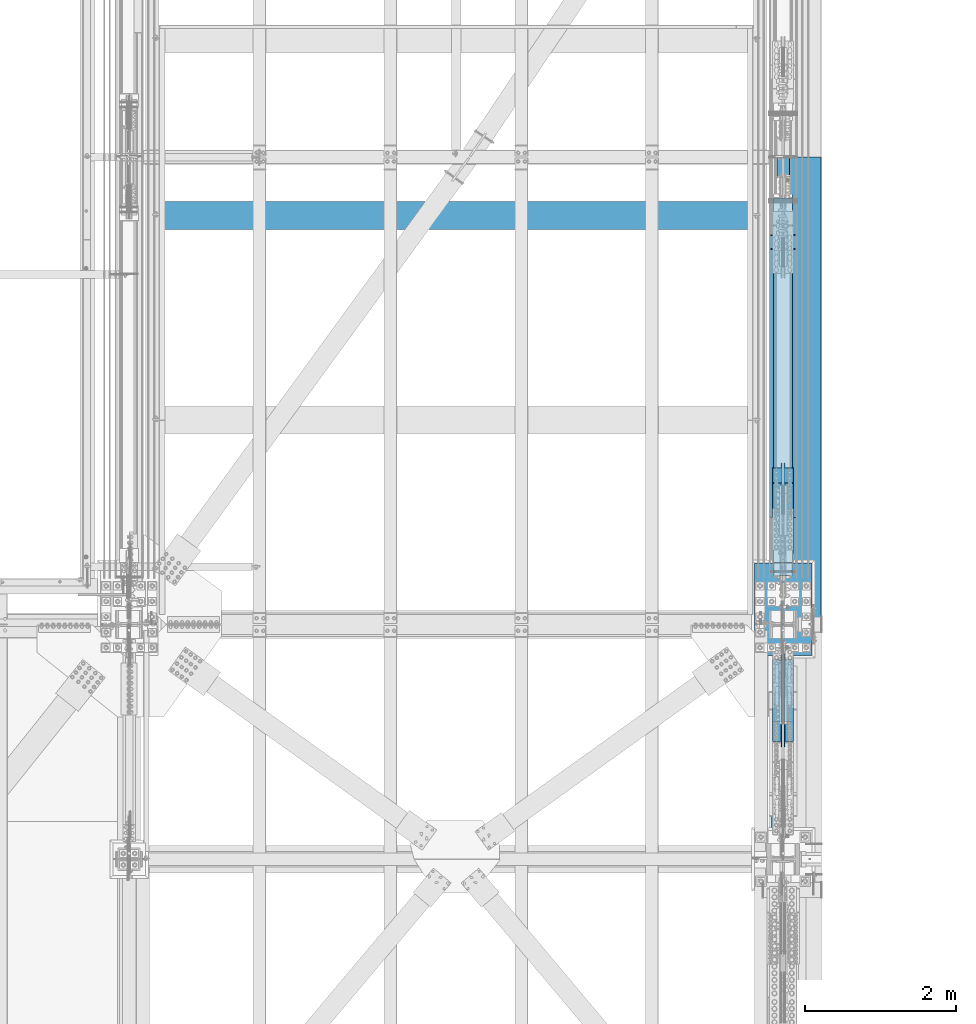
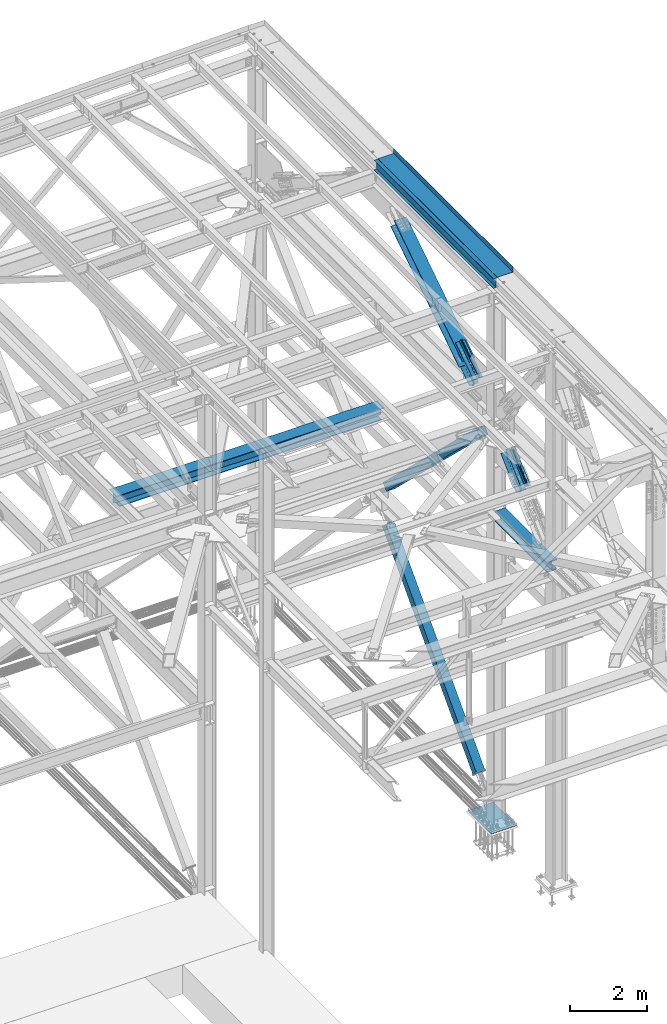
# One storey, part 1992 of 3843: 11 members, 5 beams, 8 elements without a shape of their own.
"""IFC2X3 building model written with IfcOpenShell, lengths in millimetres."""

import ifcopenshell
import ifcopenshell.guid

model = None  # the IFC model being written
_history = None  # IfcOwnerHistory: only IFC2X3 demands one
_inside = {}  # id of a spatial element -> (the spatial element, [elements in it])
_under = {}  # id of a project, library or spatial element -> (it, [spatial elements below it])
_declared = {}  # id of a project -> (the project, [libraries it declares])
_typed = {}  # id of a type object -> (the type object, [elements of that type])
_made_of = {}  # id of a material, layer set ... -> (it, [elements and type objects made of it])


def new_model(schema):
    """Start an empty IFC model of exactly this schema.

    Asked for "IFC4X3", IfcOpenShell would pick the latest addendum, in which some entities
    have other attributes; the version numbers below select the first issue.
    IFC2X3 requires an IfcOwnerHistory on every rooted entity: one is made here for all.
    """
    global model, _history
    if schema == "IFC4X3":
        model = ifcopenshell.file(schema_version=(4, 3, 0, 0))
    else:
        model = ifcopenshell.file(schema=schema)
    _inside.clear()
    _under.clear()
    _declared.clear()
    _typed.clear()
    _made_of.clear()
    _history = None
    if model.schema == "IFC2X3":
        org = make("IfcOrganization", Name="unknown")
        user = make(
            "IfcPersonAndOrganization",
            ThePerson=make("IfcPerson", FamilyName="unknown"),
            TheOrganization=org,
        )
        app = make(
            "IfcApplication",
            ApplicationDeveloper=org,
            Version="unknown",
            ApplicationFullName="unknown",
            ApplicationIdentifier="unknown",
        )
        _history = make(
            "IfcOwnerHistory",
            OwningUser=user,
            OwningApplication=app,
            ChangeAction="ADDED",
            CreationDate=0,
        )
    return model


def make(cls, **values):
    """One entity of the class cls with the attributes given. An attribute that is None is left unset."""
    return model.create_entity(
        cls, **{name: value for name, value in values.items() if value is not None}
    )


def rooted(cls, **values):
    """An entity with a GlobalId (a new one), such as an element, a storey or a relation."""
    return make(cls, GlobalId=ifcopenshell.guid.new(), OwnerHistory=_history, **values)


def si_unit(unit_type, name, prefix=None):
    """IfcSIUnit, for example si_unit("LENGTHUNIT", "METRE", prefix="MILLI")."""
    return make("IfcSIUnit", UnitType=unit_type, Prefix=prefix, Name=name)


def assignment(units):
    """IfcUnitAssignment: the units of a project."""
    return None if units is None else make("IfcUnitAssignment", Units=units)


def point(xyz):
    """IfcCartesianPoint."""
    return None if xyz is None else make("IfcCartesianPoint", Coordinates=xyz)


def direction(xyz):
    """IfcDirection."""
    return None if xyz is None else make("IfcDirection", DirectionRatios=xyz)


def frame(location, z_axis=None, x_axis=None):
    """IfcAxis2Placement3D, a coordinate frame: its origin and axes. An axis left out is left unset."""
    return make(
        "IfcAxis2Placement3D",
        Location=point(location),
        Axis=direction(z_axis),
        RefDirection=direction(x_axis),
    )


def origin_with_axes():
    """The frame at (0, 0, 0) with the z axis (0, 0, 1) and the x axis (1, 0, 0) written out."""
    return frame((0.0, 0.0, 0.0), z_axis=(0.0, 0.0, 1.0), x_axis=(1.0, 0.0, 0.0))


def place(relative_to, where):
    """IfcLocalPlacement: puts the frame where relative to a parent placement (None: the world)."""
    return make(
        "IfcLocalPlacement", PlacementRelTo=relative_to, RelativePlacement=where
    )


def context(
    kind, dimensions, precision=None, world=None, true_north=None, identifier=None
):
    """IfcGeometricRepresentationContext, for example the 3D "Model" context."""
    return make(
        "IfcGeometricRepresentationContext",
        ContextIdentifier=identifier,
        ContextType=kind,
        CoordinateSpaceDimension=dimensions,
        Precision=precision,
        WorldCoordinateSystem=world,
        TrueNorth=true_north,
    )


def subcontext(parent, identifier, kind, view, scale=None):
    """IfcGeometricRepresentationSubContext, for example "Body" below "Model"."""
    return make(
        "IfcGeometricRepresentationSubContext",
        ContextIdentifier=identifier,
        ContextType=kind,
        ParentContext=parent,
        TargetScale=scale,
        TargetView=view,
    )


def project(units=None, contexts=None):
    """IfcProject with its units and contexts."""
    return rooted(
        "IfcProject",
        Name="project",
        RepresentationContexts=contexts,
        UnitsInContext=assignment(units),
    )


def spatial(cls, under=None, at=None, **own):
    """A site, building, storey or space (cls), placed at a placement, below another one or the project."""
    s = rooted(cls, ObjectPlacement=at, **own)
    if under is not None:
        _under.setdefault(under.id(), (under, []))[1].append(s)
    return s


def faces_of(points, faces, orient=None, outer=None):
    """IfcFace entities. A face is a list of loops; a loop is a list of indices into points, from 0.

    orient and outer hold one flag for each loop. By default every Orientation is true, the
    first loop of a face is its IfcFaceOuterBound and the others are IfcFaceBound.
    """
    made = []
    for i, loops in enumerate(faces):
        bounds = []
        for j, loop in enumerate(loops):
            is_outer = j == 0 if outer is None else outer[i][j]
            bounds.append(
                make(
                    "IfcFaceOuterBound" if is_outer else "IfcFaceBound",
                    Bound=make("IfcPolyLoop", Polygon=[points[k] for k in loop]),
                    Orientation=True if orient is None else orient[i][j],
                )
            )
        made.append(make("IfcFace", Bounds=bounds))
    return made


def faceted_brep(points, faces, orient=None, outer=None, voids=None):
    """IfcFacetedBrep: a solid bounded by flat faces; with voids (closed shells), ...WithVoids."""
    shared = [point(p) for p in points]
    hull = make("IfcClosedShell", CfsFaces=faces_of(shared, faces, orient, outer))
    if voids is None:
        return make("IfcFacetedBrep", Outer=hull)
    return make(
        "IfcFacetedBrepWithVoids",
        Outer=hull,
        Voids=[
            make(cls, CfsFaces=faces_of(shared, fs, o, b)) for cls, fs, o, b in voids
        ],
    )


def shape(context_of_items, identifier, shape_type, items):
    """IfcShapeRepresentation: the items that make up one representation, for example the "Body"."""
    return make(
        "IfcShapeRepresentation",
        ContextOfItems=context_of_items,
        RepresentationIdentifier=identifier,
        RepresentationType=shape_type,
        Items=items,
    )


def material(Name=None, Category=None):
    """IfcMaterial."""
    return make("IfcMaterial", Name=Name, Category=Category)


def made_of(thing, what):
    """Note that an element or type object is made of a material, layer set ...; save() writes the relation."""
    if what is not None:
        _made_of.setdefault(what.id(), (what, []))[1].append(thing)
    return thing


def type_object(cls, material=None, **own):
    """A type object (cls), such as IfcWallType, which elements share."""
    return made_of(rooted(cls, **own), material)


def element(
    cls,
    number,
    at=None,
    inside=None,
    cuts=None,
    type_object=None,
    material=None,
    context=None,
    identifier="Body",
    shape_type=None,
    held_by="IfcProductDefinitionShape",
    body=None,
    shapes=None,
    **own,
):
    """One element of the class cls, such as IfcWall. Its Tag is "e" and its number.

    at: its placement. inside: the storey or other place that contains it. cuts: it is an
    opening in that element (IfcRelVoidsElement). A single representation is given by context,
    identifier, shape_type and body (its items); several are given by shapes. held_by: the class
    of the entity that holds the representations. save() writes the other relations.
    """
    e = rooted(cls, Tag="e%d" % number, ObjectPlacement=at, **own)
    if body is not None:
        shapes = [shape(context, identifier, shape_type, body)]
    if shapes is not None:
        e.Representation = make(held_by, Representations=shapes)
    if inside is not None:
        _inside.setdefault(inside.id(), (inside, []))[1].append(e)
    if cuts is not None:
        rooted(
            "IfcRelVoidsElement", RelatingBuildingElement=cuts, RelatedOpeningElement=e
        )
    if type_object is not None:
        _typed.setdefault(type_object.id(), (type_object, []))[1].append(e)
    return made_of(e, material)


def aggregate(whole, parts):
    """IfcRelAggregates: a whole, such as a stair, and the parts it consists of."""
    return rooted("IfcRelAggregates", RelatingObject=whole, RelatedObjects=parts)


def save(model, path):
    """Write the relations noted so far, then the file.

    IfcRelAggregates (storeys below a building ...), IfcRelContainedInSpatialStructure (elements
    in a storey), IfcRelDefinesByType, IfcRelAssociatesMaterial and IfcRelDeclares: one each for
    every whole, place, type object, material and project.
    """
    for whole, parts in _under.values():
        aggregate(whole, parts)
    for where, things in _inside.values():
        rooted(
            "IfcRelContainedInSpatialStructure",
            RelatedElements=things,
            RelatingStructure=where,
        )
    for kind, things in _typed.values():
        rooted("IfcRelDefinesByType", RelatedObjects=things, RelatingType=kind)
    for what, things in _made_of.values():
        rooted("IfcRelAssociatesMaterial", RelatedObjects=things, RelatingMaterial=what)
    for by, libraries in _declared.values():
        rooted("IfcRelDeclares", RelatingContext=by, RelatedDefinitions=libraries)
    model.write(path)


model = new_model("IFC2X3")

# Units and contexts
model_context = context("Model", 3, precision=1e-05, world=origin_with_axes())
body_context = subcontext(model_context, "Body", "Model", "MODEL_VIEW")
ifc_project = project(units=[si_unit("LENGTHUNIT", "METRE", prefix="MILLI"), si_unit("AREAUNIT", "SQUARE_METRE"), si_unit("VOLUMEUNIT", "CUBIC_METRE"), si_unit("MASSUNIT", "GRAM", prefix="KILO"), si_unit("TIMEUNIT", "SECOND"), si_unit("PLANEANGLEUNIT", "RADIAN"), si_unit("SOLIDANGLEUNIT", "STERADIAN"), si_unit("THERMODYNAMICTEMPERATUREUNIT", "DEGREE_CELSIUS"), si_unit("LUMINOUSINTENSITYUNIT", "LUMEN")], contexts=[model_context])

# Site, building, storey
site_placement = place(None, origin_with_axes())
site = spatial("IfcSite", under=ifc_project, at=site_placement, CompositionType="ELEMENT")
building_placement = place(site_placement, origin_with_axes())
building = spatial("IfcBuilding", under=site, at=building_placement, Name="Undefined", CompositionType="ELEMENT")
storey_placement = place(building_placement, origin_with_axes())
storey = spatial("IfcBuildingStorey", under=building, at=storey_placement, Name="Undefined", CompositionType="ELEMENT", Elevation=0.0)

# Assembly, beam
assembly_1_placement = place(storey_placement, origin_with_axes())
assembly_1 = element("IfcElementAssembly", 1, at=assembly_1_placement, inside=storey, Name="BEAM", AssemblyPlace="NOTDEFINED", PredefinedType="RIGID_FRAME")
ifc_material_1 = material(Name="STEEL/A992")
beam_type_1 = type_object("IfcBeamType", Name="W12X26", PredefinedType="NOTDEFINED")
beam_1_placement = place(assembly_1_placement, frame((85648.8000000032, 92214.7, 46612.1750000001), z_axis=(0.0, 0.0, 1.0), x_axis=(0.0, 1.0, 0.0)))
beam_1 = element("IfcBeam", 2, at=beam_1_placement, type_object=beam_type_1, material=ifc_material_1, Name="BEAM", ObjectType="W12X26", context=body_context, shape_type="Brep", body=[
    faceted_brep([(0.0, 82.5500000000029, -155.574999999997), (0.0, 82.5500000000029, -146.050000000003), (6172.19999999998, 82.5500000000029, -146.050000000003), (6172.19999999998, 82.5500000000029, -155.574999999997), (0.0, 3.17500000000291, -146.050000000003), (6172.19999999998, 3.17500000000291, -146.050000000003), (0.0, 3.17500000000291, 146.050000000003), (6172.19999999998, 3.17500000000291, 146.050000000003), (0.0, 82.5500000000029, 146.050000000003), (6172.19999999998, 82.5500000000029, 146.050000000003), (0.0, 82.5500000000029, 155.574999999997), (6172.19999999998, 82.5500000000029, 155.574999999997), (0.0, -82.5500000000029, 155.574999999997), (6172.19999999998, -82.5500000000029, 155.574999999997), (0.0, -82.5500000000029, 146.050000000003), (6172.19999999998, -82.5500000000029, 146.050000000003), (0.0, -3.17500000000291, 146.050000000003), (6172.19999999998, -3.17500000000291, 146.050000000003), (0.0, -3.17500000000291, -146.050000000003), (6172.19999999998, -3.17500000000291, -146.050000000003), (0.0, -82.5500000000029, -146.050000000003), (6172.19999999998, -82.5500000000029, -146.050000000003), (0.0, -82.5500000000029, -155.574999999997), (6172.19999999998, -82.5500000000029, -155.574999999997)], [[[0, 1, 2, 3]], [[1, 4, 5, 2]], [[4, 6, 7, 5]], [[6, 8, 9, 7]], [[8, 10, 11, 9]], [[10, 12, 13, 11]], [[12, 14, 15, 13]], [[14, 16, 17, 15]], [[16, 18, 19, 17]], [[18, 20, 21, 19]], [[20, 22, 23, 21]], [[22, 0, 3, 23]], [[5, 7, 9, 11, 13, 15, 17, 19, 21, 23, 3, 2]], [[22, 20, 18, 16, 14, 12, 10, 8, 6, 4, 1, 0]]]),
])

# Assembly, member
assembly_2_placement = place(storey_placement, origin_with_axes())
assembly_2 = element("IfcElementAssembly", 3, at=assembly_2_placement, inside=storey, Name="None", AssemblyPlace="NOTDEFINED", PredefinedType="RIGID_FRAME")
member_type_1 = type_object("IfcMemberType", Name="HSS10X10X1/4", PredefinedType="NOTDEFINED")
member_1_placement = place(assembly_2_placement, frame((85648.8, 97760.3796907054, 36855.6774993452), z_axis=(-1.0, 0.0, 0.0), x_axis=(0.0, -0.720230928336236, 0.693734394323883)))
member_1 = element("IfcMember", 4, at=member_1_placement, type_object=member_type_1, material=ifc_material_1, Name="None", ObjectType="HSS10X10X1/4", context=body_context, shape_type="Brep", body=[
    faceted_brep([(2.00088834390044e-10, 120.650000000089, -120.649999999994), (-2.03726813197136e-10, -120.650000000081, -120.649999999994), (6686.54999972145, -120.649999979905, -120.649999999994), (6686.54999972065, 120.650000020963, -120.649999999994), (-2.03726813197136e-10, -120.650000000081, 120.649999999994), (6686.54999972145, -120.649999979905, 120.649999999994), (2.00088834390044e-10, 120.650000000089, 120.649999999994), (6686.54999972065, 120.650000020963, 120.649999999994), (2.16459739021957e-10, 127.000000000087, -127.0), (2.16459739021957e-10, 127.000000000087, 127.0), (6686.54999972065, 127.000000020969, 127.0), (6686.54999972065, 127.000000020969, -127.0), (-2.14640749618411e-10, -127.00000000008, 127.0), (6686.54999972146, -126.999999979933, 127.0), (-2.14640749618411e-10, -127.00000000008, -127.0), (6686.54999972146, -126.999999979933, -127.0)], [[[0, 1, 2, 3]], [[1, 4, 5, 2]], [[4, 6, 7, 5]], [[6, 0, 3, 7]], [[8, 9, 10, 11]], [[9, 12, 13, 10]], [[12, 14, 15, 13]], [[14, 8, 11, 15]], [[13, 15, 11, 10], [5, 7, 3, 2]], [[14, 12, 9, 8], [6, 4, 1, 0]]]),
])
aggregate(assembly_2, [member_1])

assembly_3_placement = place(storey_placement, origin_with_axes())
assembly_3 = element("IfcElementAssembly", 5, at=assembly_3_placement, inside=storey, Name="None", AssemblyPlace="NOTDEFINED", PredefinedType="RIGID_FRAME")
member_2_placement = place(assembly_3_placement, frame((85648.8, 93103.6699261647, 30626.488348224), z_axis=(1.0, 0.0, 0.0), x_axis=(0.0, 0.684573417924221, 0.728943917919308)))
member_2 = element("IfcMember", 6, at=member_2_placement, type_object=member_type_1, material=ifc_material_1, Name="None", ObjectType="HSS10X10X1/4", context=body_context, shape_type="Brep", body=[
    faceted_brep([(2.00088834390044e-10, 120.650000000089, -120.649999999994), (-2.03726813197136e-10, -120.650000000081, -120.649999999994), (6864.34999990163, -120.649999978414, -120.649999999994), (6864.34999990151, 120.650000021516, -120.649999999994), (-2.03726813197136e-10, -120.650000000081, 120.649999999994), (6864.34999990163, -120.649999978414, 120.649999999994), (2.00088834390044e-10, 120.650000000089, 120.649999999994), (6864.34999990151, 120.650000021516, 120.649999999994), (2.16459739021957e-10, 127.000000000087, -127.0), (2.16459739021957e-10, 127.000000000087, 127.0), (6864.34999990149, 127.000000021508, 127.0), (6864.34999990149, 127.000000021508, -127.0), (-2.14640749618411e-10, -127.00000000008, 127.0), (6864.34999990163, -126.999999978405, 127.0), (-2.14640749618411e-10, -127.00000000008, -127.0), (6864.34999990163, -126.999999978405, -127.0)], [[[0, 1, 2, 3]], [[1, 4, 5, 2]], [[4, 6, 7, 5]], [[6, 0, 3, 7]], [[8, 9, 10, 11]], [[9, 12, 13, 10]], [[12, 14, 15, 13]], [[14, 8, 11, 15]], [[13, 15, 11, 10], [5, 7, 3, 2]], [[14, 12, 9, 8], [6, 4, 1, 0]]]),
])
aggregate(assembly_3, [member_2])

# Assembly, beam
assembly_4_placement = place(storey_placement, origin_with_axes())
assembly_4 = element("IfcElementAssembly", 7, at=assembly_4_placement, inside=storey, Name="BEAM", AssemblyPlace="NOTDEFINED", PredefinedType="RIGID_FRAME")
beam_type_2 = type_object("IfcBeamType", Name="W12X87", PredefinedType="NOTDEFINED")
beam_2_placement = place(assembly_4_placement, frame((85648.8000002308, 89115.9000004197, 39427.15), z_axis=(0.0, 0.0, 1.0), x_axis=(0.0, 1.0, 0.0)))
beam_2 = element("IfcBeam", 8, at=beam_2_placement, type_object=beam_type_2, material=ifc_material_1, Name="BEAM", ObjectType="W12X87", context=body_context, shape_type="Brep", body=[
    faceted_brep([(2900.36250000031, -153.987500000003, 138.112500000003), (2900.36250000031, -153.987500000003, 158.75), (227.814601116072, -153.987500000003, 158.75), (215.89999999998, -153.987500000003, 138.112500000003), (2900.36250000031, -147.637500000012, 158.75), (2900.36250000031, 147.637499999983, 158.75), (2900.36250000031, 153.987500000003, 158.75), (227.814601116072, 153.987500000003, 158.75), (2900.36250000031, 153.987500000003, 138.112500000003), (215.89999999998, 153.987500000003, 138.112500000003), (2900.36250000031, 147.637499999983, 138.112500000003), (2900.36250000031, 6.35000000000582, 138.112500000003), (215.89999999998, 6.35000000000582, 138.112500000003), (268.679934809377, -6.35000000000582, -130.671038190994), (268.679934809377, 6.35000000000582, -130.671038190994), (255.260999999984, 6.35000000000582, -137.715499999998), (255.260999999984, -6.35000000000582, -137.715499999998), (272.344200108389, -6.35000000000582, -127.262644376198), (272.344200108389, 6.35000000000582, -127.262644376198), (273.774859921614, -6.35000000000582, -122.46710466966), (273.774859921614, 6.35000000000582, -122.46710466966), (272.576993509821, -6.35000000000582, -117.608184559416), (272.576993509821, 6.35000000000582, -117.608184559416), (269.081261093219, -6.35000000000582, -114.027145122374), (269.081261093219, 6.35000000000582, -114.027145122374), (264.252628079572, -6.35000000000582, -112.712500000001), (264.252628079572, 6.35000000000582, -112.712500000001), (219.074999999983, -6.35000000000582, -112.712500000001), (219.074999999983, 6.35000000000582, -112.712500000001), (219.074999999983, -6.35000000000582, 112.712500000001), (219.074999999983, 6.35000000000582, 112.712500000001), (264.579628079562, -6.35000000000582, 112.712500000001), (264.579628079562, 6.35000000000582, 112.712500000001), (269.408261093209, -6.35000000000582, 114.027145122374), (269.408261093209, 6.35000000000582, 114.027145122374), (272.903993509826, -6.35000000000582, 117.608184559416), (272.903993509826, 6.35000000000582, 117.608184559416), (274.101859921604, -6.35000000000582, 122.46710466966), (274.101859921604, 6.35000000000582, 122.46710466966), (272.67120010838, -6.35000000000582, 127.262644376206), (272.67120010838, 6.35000000000582, 127.262644376206), (269.006934809368, -6.35000000000582, 130.671038190994), (269.006934809368, 6.35000000000582, 130.671038190994), (255.587999999974, -6.35000000000582, 137.715499999998), (255.587999999974, 6.35000000000582, 137.715499999998), (215.89999999998, -6.35000000000582, 137.715499999998), (215.89999999998, 6.35000000000582, 137.715499999998), (215.89999999998, -6.35000000000582, 138.112500000003), (2900.36250000031, -6.35000000000582, 138.112500000003), (2900.36250000031, -147.637500000012, 138.112500000003), (2900.36250000031, -153.987500000003, -158.75), (2900.36250000031, -153.987500000003, -138.112500000003), (227.814615981624, -153.987500000003, -138.112500000003), (215.89999999998, -153.987500000003, -158.75), (2900.36250000031, 153.987500000003, -158.75), (2900.36250000031, 147.637499999983, -158.75), (2900.36250000031, -147.637500000012, -158.75), (215.89999999998, 153.987500000003, -158.75), (2900.36250000031, 153.987500000003, -138.112500000003), (227.814615981624, 153.987500000003, -138.112500000003), (2900.36250000031, 147.637499999983, -138.112500000003), (2900.36250000031, 6.35000000000582, -138.112500000003), (2900.36250000031, 6.35000000000582, -115.040000000001), (2900.36250000031, 6.35000000000582, 115.040000000001), (2900.36250000031, -6.35000000000582, -138.112500000003), (2900.36250000031, -147.637500000012, -138.112500000003), (227.814615981624, 6.35000000000582, -138.112500000003), (228.043807990805, 6.35000000000582, -137.715499999998), (228.043807990805, -6.35000000000582, -137.715499999998), (227.814615981624, -6.35000000000582, -138.112500000003)], [[[0, 1, 2, 3]], [[1, 4, 5, 6, 7, 2]], [[6, 8, 9, 7]], [[8, 10, 11, 12, 9]], [[13, 14, 15, 16]], [[17, 18, 14, 13]], [[19, 20, 18, 17]], [[21, 22, 20, 19]], [[23, 24, 22, 21]], [[25, 26, 24, 23]], [[26, 25, 27, 28]], [[29, 30, 28, 27]], [[31, 32, 30, 29]], [[33, 34, 32, 31]], [[35, 36, 34, 33]], [[37, 38, 36, 35]], [[39, 40, 38, 37]], [[41, 42, 40, 39]], [[43, 44, 42, 41]], [[44, 43, 45, 46]], [[46, 45, 47, 12]], [[2, 7, 9, 12, 47, 3]], [[48, 49, 0, 3, 47]], [[50, 51, 52, 53]], [[54, 55, 56, 50, 53, 57]], [[58, 54, 57, 59]], [[60, 61, 62, 63, 11, 10, 8, 6, 5, 4, 1, 0, 49, 48, 64, 65, 51, 50, 56, 55, 54, 58]], [[15, 14, 18, 20, 22, 24, 26, 28, 30, 32, 34, 36, 38, 40, 42, 44, 46, 12, 11, 63, 62, 61, 66, 67]], [[16, 15, 67, 68]], [[64, 48, 47, 45, 43, 41, 39, 37, 35, 33, 31, 29, 27, 25, 23, 21, 19, 17, 13, 16, 68, 69]], [[51, 65, 64, 69, 52]], [[68, 67, 66, 59, 57, 53, 52, 69]], [[61, 60, 58, 59, 66]]]),
])
aggregate(assembly_4, [beam_2])

# Assembly, members
assembly_5_placement = place(storey_placement, origin_with_axes())
assembly_5 = element("IfcElementAssembly", 9, at=assembly_5_placement, inside=storey, AssemblyPlace="NOTDEFINED", PredefinedType="RIGID_FRAME")
ifc_material_2 = material(Name="STEEL/A572-50")
member_type_2 = type_object("IfcMemberType", Name="L5X5X1/2", PredefinedType="NOTDEFINED")
member_3_placement = place(assembly_5_placement, frame((85725.0000002308, 91786.6453578106, 41524.4232588973), z_axis=(0.0, 0.672974507774426, -0.739665675752072), x_axis=(0.0, -0.739665675752075, -0.672974507774422)))
member_3 = element("IfcMember", 10, at=member_3_placement, type_object=member_type_2, material=ifc_material_2, Name="ANGLE", ObjectType="L5X5X1/2", context=body_context, shape_type="Brep", body=[
    faceted_brep([(-1.01863406598568e-10, 63.5, -63.5000000002037), (1.01863406598568e-10, 63.5, 63.5000000002074), (1104.90000001364, 63.5, 63.500000003929), (1104.90000001345, 63.5, -63.499999996493), (1.01863406598568e-10, 50.8000000000029, 63.5000000002074), (1104.90000001364, 50.8000000000029, 63.500000003929), (0.0, 50.8000000000029, -50.8000000000029), (1104.90000001348, 50.8000000000029, -50.7999999964522), (-7.27595761418343e-11, -63.5, -50.8000000001666), (1104.90000001348, -63.5, -50.7999999964522), (-1.01863406598568e-10, -63.5, -63.5000000002037), (1104.90000001345, -63.5, -63.499999996493)], [[[0, 1, 2, 3]], [[1, 4, 5, 2]], [[4, 6, 7, 5]], [[6, 8, 9, 7]], [[8, 10, 11, 9]], [[10, 0, 3, 11]], [[5, 7, 9, 11, 3, 2]], [[10, 8, 6, 4, 1, 0]]]),
])
member_4_placement = place(assembly_5_placement, frame((85725.0000002308, 90638.2011730507, 41144.8616959397), z_axis=(0.0, -0.672974507774418, 0.739665675752079), x_axis=(0.0, 0.739665675752077, 0.672974507774421)))
member_4 = element("IfcMember", 11, at=member_4_placement, type_object=member_type_2, material=ifc_material_2, Name="ANGLE", ObjectType="L5X5X1/2", context=body_context, shape_type="Brep", body=[
    faceted_brep([(-1.01863406598568e-10, 63.5, -63.5000000002037), (1.01863406598568e-10, 63.5, 63.5000000002074), (1104.90000001364, 63.5, 63.500000003929), (1104.90000001345, 63.5, -63.499999996493), (1.01863406598568e-10, 50.8000000000029, 63.5000000002074), (1104.90000001364, 50.8000000000029, 63.500000003929), (0.0, 50.8000000000029, -50.8000000000029), (1104.90000001348, 50.8000000000029, -50.7999999964522), (-7.27595761418343e-11, -63.5, -50.8000000001666), (1104.90000001348, -63.5, -50.7999999964522), (-1.01863406598568e-10, -63.5, -63.5000000002037), (1104.90000001345, -63.5, -63.499999996493)], [[[0, 1, 2, 3]], [[1, 4, 5, 2]], [[4, 6, 7, 5]], [[6, 8, 9, 7]], [[8, 10, 11, 9]], [[10, 0, 3, 11]], [[5, 7, 9, 11, 3, 2]], [[10, 8, 6, 4, 1, 0]]]),
])
member_5_placement = place(assembly_5_placement, frame((85572.6000002308, 90969.3887526866, 40780.8537252655), z_axis=(0.0, 0.672974507774426, -0.739665675752072), x_axis=(0.0, 0.739665675752077, 0.672974507774421)))
member_5 = element("IfcMember", 12, at=member_5_placement, type_object=member_type_2, material=ifc_material_2, Name="ANGLE", ObjectType="L5X5X1/2", context=body_context, shape_type="Brep", body=[
    faceted_brep([(-1.01863406598568e-10, 63.5, -63.5000000002037), (1.01863406598568e-10, 63.5, 63.5000000002074), (1104.90000001364, 63.5, 63.500000003929), (1104.90000001345, 63.5, -63.499999996493), (1.01863406598568e-10, 50.8000000000029, 63.5000000002074), (1104.90000001364, 50.8000000000029, 63.500000003929), (0.0, 50.8000000000029, -50.8000000000029), (1104.90000001348, 50.8000000000029, -50.7999999964522), (-7.27595761418343e-11, -63.5, -50.8000000001666), (1104.90000001348, -63.5, -50.7999999964522), (-1.01863406598568e-10, -63.5, -63.5000000002037), (1104.90000001345, -63.5, -63.499999996493)], [[[0, 1, 2, 3]], [[1, 4, 5, 2]], [[4, 6, 7, 5]], [[6, 8, 9, 7]], [[8, 10, 11, 9]], [[10, 0, 3, 11]], [[5, 7, 9, 11, 3, 2]], [[10, 8, 6, 4, 1, 0]]]),
])
member_6_placement = place(assembly_5_placement, frame((85572.6000002308, 91455.4577781746, 41888.4312295715), z_axis=(0.0, -0.672974507774418, 0.739665675752079), x_axis=(0.0, -0.739665675752075, -0.672974507774422)))
member_6 = element("IfcMember", 13, at=member_6_placement, type_object=member_type_2, material=ifc_material_2, Name="ANGLE", ObjectType="L5X5X1/2", context=body_context, shape_type="Brep", body=[
    faceted_brep([(-1.01863406598568e-10, 63.5, -63.5000000002037), (1.01863406598568e-10, 63.5, 63.5000000002074), (1104.90000001364, 63.5, 63.500000003929), (1104.90000001345, 63.5, -63.499999996493), (1.01863406598568e-10, 50.8000000000029, 63.5000000002074), (1104.90000001364, 50.8000000000029, 63.500000003929), (0.0, 50.8000000000029, -50.8000000000029), (1104.90000001348, 50.8000000000029, -50.7999999964522), (-7.27595761418343e-11, -63.5, -50.8000000001666), (1104.90000001348, -63.5, -50.7999999964522), (-1.01863406598568e-10, -63.5, -63.5000000002037), (1104.90000001345, -63.5, -63.499999996493)], [[[0, 1, 2, 3]], [[1, 4, 5, 2]], [[4, 6, 7, 5]], [[6, 8, 9, 7]], [[8, 10, 11, 9]], [[10, 0, 3, 11]], [[5, 7, 9, 11, 3, 2]], [[10, 8, 6, 4, 1, 0]]]),
])
aggregate(assembly_5, [member_3, member_4, member_5, member_6])

assembly_6_placement = place(storey_placement, origin_with_axes())
assembly_6 = element("IfcElementAssembly", 14, at=assembly_6_placement, inside=storey, AssemblyPlace="NOTDEFINED", PredefinedType="RIGID_FRAME")
member_7_placement = place(assembly_6_placement, frame((85724.9999999863, 93126.5724328215, 43078.8695559392), z_axis=(0.0, -0.545564039261356, 0.838069137401464), x_axis=(0.0, 0.838069137401467, 0.545564039261351)))
member_7 = element("IfcMember", 15, at=member_7_placement, type_object=member_type_2, material=ifc_material_2, Name="ANGLE", ObjectType="L5X5X1/2", context=body_context, shape_type="Brep", body=[
    faceted_brep([(-1.01863406598568e-10, 63.5, -63.5000000002037), (1.01863406598568e-10, 63.5, 63.5000000002074), (1104.90000001364, 63.5, 63.500000003929), (1104.90000001345, 63.5, -63.499999996493), (1.01863406598568e-10, 50.8000000000029, 63.5000000002074), (1104.90000001364, 50.8000000000029, 63.500000003929), (0.0, 50.8000000000029, -50.8000000000029), (1104.90000001348, 50.8000000000029, -50.7999999964522), (-7.27595761418343e-11, -63.5, -50.8000000001666), (1104.90000001348, -63.5, -50.7999999964522), (-1.01863406598568e-10, -63.5, -63.5000000002037), (1104.90000001345, -63.5, -63.499999996493)], [[[0, 1, 2, 3]], [[1, 4, 5, 2]], [[4, 6, 7, 5]], [[6, 8, 9, 7]], [[8, 10, 11, 9]], [[10, 0, 3, 11]], [[5, 7, 9, 11, 3, 2]], [[10, 8, 6, 4, 1, 0]]]),
])
member_8_placement = place(assembly_6_placement, frame((85724.9999999863, 94315.8442281005, 43277.2110972113), z_axis=(0.0, 0.545564039261343, -0.838069137401472), x_axis=(0.0, -0.838069137401464, -0.545564039261356)))
member_8 = element("IfcMember", 16, at=member_8_placement, type_object=member_type_2, material=ifc_material_2, Name="ANGLE", ObjectType="L5X5X1/2", context=body_context, shape_type="Brep", body=[
    faceted_brep([(-1.01863406598568e-10, 63.5, -63.5000000002037), (1.01863406598568e-10, 63.5, 63.5000000002074), (1104.90000001364, 63.5, 63.500000003929), (1104.90000001345, 63.5, -63.499999996493), (1.01863406598568e-10, 50.8000000000029, 63.5000000002074), (1104.90000001364, 50.8000000000029, 63.500000003929), (0.0, 50.8000000000029, -50.8000000000029), (1104.90000001348, 50.8000000000029, -50.7999999964522), (-7.27595761418343e-11, -63.5, -50.8000000001666), (1104.90000001348, -63.5, -50.7999999964522), (-1.01863406598568e-10, -63.5, -63.5000000002037), (1104.90000001345, -63.5, -63.499999996493)], [[[0, 1, 2, 3]], [[1, 4, 5, 2]], [[4, 6, 7, 5]], [[6, 8, 9, 7]], [[8, 10, 11, 9]], [[10, 0, 3, 11]], [[5, 7, 9, 11, 3, 2]], [[10, 8, 6, 4, 1, 0]]]),
])
member_9_placement = place(assembly_6_placement, frame((85572.5999999863, 94052.5550227507, 43681.6632629262), z_axis=(0.0, -0.545564039261356, 0.838069137401464), x_axis=(0.0, -0.838069137401464, -0.545564039261356)))
member_9 = element("IfcMember", 17, at=member_9_placement, type_object=member_type_2, material=ifc_material_2, Name="ANGLE", ObjectType="L5X5X1/2", context=body_context, shape_type="Brep", body=[
    faceted_brep([(-1.01863406598568e-10, 63.5, -63.5000000002037), (1.01863406598568e-10, 63.5, 63.5000000002074), (1104.90000001364, 63.5, 63.500000003929), (1104.90000001345, 63.5, -63.499999996493), (1.01863406598568e-10, 50.8000000000029, 63.5000000002074), (1104.90000001364, 50.8000000000029, 63.500000003929), (0.0, 50.8000000000029, -50.8000000000029), (1104.90000001348, 50.8000000000029, -50.7999999964522), (-7.27595761418343e-11, -63.5, -50.8000000001666), (1104.90000001348, -63.5, -50.7999999964522), (-1.01863406598568e-10, -63.5, -63.5000000002037), (1104.90000001345, -63.5, -63.499999996493)], [[[0, 1, 2, 3]], [[1, 4, 5, 2]], [[4, 6, 7, 5]], [[6, 8, 9, 7]], [[8, 10, 11, 9]], [[10, 0, 3, 11]], [[5, 7, 9, 11, 3, 2]], [[10, 8, 6, 4, 1, 0]]]),
])
member_10_placement = place(assembly_6_placement, frame((85572.5999999863, 93389.8616381713, 42674.4173902243), z_axis=(0.0, 0.545564039261343, -0.838069137401472), x_axis=(0.0, 0.838069137401467, 0.545564039261351)))
member_10 = element("IfcMember", 18, at=member_10_placement, type_object=member_type_2, material=ifc_material_2, Name="ANGLE", ObjectType="L5X5X1/2", context=body_context, shape_type="Brep", body=[
    faceted_brep([(-1.01863406598568e-10, 63.5, -63.5000000002037), (1.01863406598568e-10, 63.5, 63.5000000002074), (1104.90000001364, 63.5, 63.500000003929), (1104.90000001345, 63.5, -63.499999996493), (1.01863406598568e-10, 50.8000000000029, 63.5000000002074), (1104.90000001364, 50.8000000000029, 63.500000003929), (0.0, 50.8000000000029, -50.8000000000029), (1104.90000001348, 50.8000000000029, -50.7999999964522), (-7.27595761418343e-11, -63.5, -50.8000000001666), (1104.90000001348, -63.5, -50.7999999964522), (-1.01863406598568e-10, -63.5, -63.5000000002037), (1104.90000001345, -63.5, -63.499999996493)], [[[0, 1, 2, 3]], [[1, 4, 5, 2]], [[4, 6, 7, 5]], [[6, 8, 9, 7]], [[8, 10, 11, 9]], [[10, 0, 3, 11]], [[5, 7, 9, 11, 3, 2]], [[10, 8, 6, 4, 1, 0]]]),
])

# Beam
ifc_material_3 = material(Name="STEEL/A36")
beam_type_3 = type_object("IfcBeamType", PredefinedType="NOTDEFINED")
beam_3_placement = place(assembly_1_placement, frame((85680.5500000031, 95300.8, 46772.5125000001), z_axis=(0.0, -1.0, 0.0), x_axis=(1.0, 0.0, 0.0)))
beam_3 = element("IfcBeam", 19, at=beam_3_placement, type_object=beam_type_3, material=ifc_material_3, Name="BENT_PLATE", context=body_context, shape_type="Brep", body=[
    faceted_brep([(0.0, -4.76249999999709, -3086.10000000001), (0.0, -4.76249999999709, 3086.10000000001), (0.0, 4.76249999999709, 3086.10000000001), (0.0, 4.76249999999709, -3086.10000000001), (466.724999999991, 4.76249999999709, 3086.10000000001), (466.724999999991, 4.76249999999709, -3086.10000000001), (476.249999999985, -4.76249999999709, -3086.10000000001), (476.249999999985, -4.76249999999709, 3086.10000000001), (466.725000000006, 160.337499999994, 3086.10000000001), (466.725000000006, 160.337499999994, -3086.10000000001), (476.25, 160.337499999994, 3086.10000000001), (476.25, 160.337499999994, -3086.10000000001)], [[[0, 1, 2, 3]], [[3, 2, 4, 5]], [[1, 0, 6, 7]], [[5, 4, 8, 9]], [[4, 2, 1, 7, 10, 8]], [[7, 6, 11, 10]], [[6, 0, 3, 5, 9, 11]], [[10, 11, 9, 8]]]),
])

aggregate(assembly_1, [beam_3, beam_1])

# Member
member_type_3 = type_object("IfcMemberType", Name="W14X90", PredefinedType="NOTDEFINED")
member_11_placement = place(assembly_6_placement, frame((85648.7999999863, 92214.6999984407, 42197.3375013331), z_axis=(0.0, -0.545564039261356, 0.838069137401464), x_axis=(0.0, 0.838069137401467, 0.545564039261351)))
member_11 = element("IfcMember", 20, at=member_11_placement, type_object=member_type_3, material=ifc_material_1, ObjectType="W14X90", context=body_context, shape_type="Brep", body=[
    faceted_brep([(1803.94433296585, 184.149999999994, -177.800000003344), (1803.94433296584, 184.149999999994, -160.337500003314), (6026.71527085324, 184.149999999994, -160.337500010299), (6026.71527085325, 184.149999999994, -177.800000010329), (1803.94433296584, 5.55624999999418, -160.337500003314), (6026.71527085324, 5.55624999999418, -160.337500010299), (1803.94433296584, 5.55624999999418, 160.337499997344), (6026.71527085325, 5.55624999999418, 160.337499990352), (1803.94433296584, 184.149999999994, 160.337499997344), (6026.71527085325, 184.149999999994, 160.337499990352), (1803.94433296584, 184.149999999994, 177.799999997389), (6026.71527085325, 184.149999999994, 177.799999990397), (1803.94433296584, -184.149999999994, 177.799999997389), (6026.71527085325, -184.149999999994, 177.799999990397), (1803.94433296584, -184.149999999994, 160.337499997344), (6026.71527085325, -184.149999999994, 160.337499990352), (1803.94433296584, -5.55624999999418, 160.337499997344), (6026.71527085325, -5.55624999999418, 160.337499990352), (1803.94433296584, -5.55624999999418, -160.337500003314), (6026.71527085324, -5.55624999999418, -160.337500010299), (1803.94433296584, -184.149999999994, -160.337500003314), (6026.71527085324, -184.149999999994, -160.337500010299), (1803.94433296585, -184.149999999994, -177.800000003344), (6026.71527085325, -184.149999999994, -177.800000010329)], [[[0, 1, 2, 3]], [[1, 4, 5, 2]], [[4, 6, 7, 5]], [[6, 8, 9, 7]], [[8, 10, 11, 9]], [[10, 12, 13, 11]], [[12, 14, 15, 13]], [[14, 16, 17, 15]], [[16, 18, 19, 17]], [[18, 20, 21, 19]], [[20, 22, 23, 21]], [[22, 0, 3, 23]], [[5, 7, 9, 11, 13, 15, 17, 19, 21, 23, 3, 2]], [[22, 20, 18, 16, 14, 12, 10, 8, 6, 4, 1, 0]]]),
])

aggregate(assembly_6, [member_7, member_8, member_9, member_10, member_11])

# Assembly, beam
assembly_7_placement = place(storey_placement, origin_with_axes())
assembly_7 = element("IfcElementAssembly", 21, at=assembly_7_placement, inside=storey, Name="BEAM", AssemblyPlace="NOTDEFINED", PredefinedType="RIGID_FRAME")
beam_type_4 = type_object("IfcBeamType", Name="W14X90", PredefinedType="NOTDEFINED")
beam_4_placement = place(assembly_7_placement, frame((77317.6, 97616.764071, 39446.2), z_axis=(0.0, 0.0, 1.0), x_axis=(1.0, 0.0, 0.0)))
beam_4 = element("IfcBeam", 22, at=beam_4_placement, type_object=beam_type_4, material=ifc_material_1, Name="BEAM", ObjectType="W14X90", context=body_context, shape_type="Brep", body=[
    faceted_brep([(18.2562499999913, -5.55625000000146, -146.050000000003), (18.2562499999913, 5.55625000000146, -146.050000000003), (94.4562501907058, 5.55625000000146, -146.050000000003), (94.4562501907058, -5.55625000000146, -146.050000000003), (99.3163297087449, 5.55625000000146, -147.016729922594), (99.3163297087449, -5.55625000000146, -147.016729922594), (103.436506176906, 5.55625000000146, -149.769743823068), (103.436506176906, -5.55625000000146, -149.769743823068), (106.189520077387, 5.55625000000146, -153.889920291222), (106.189520077387, -5.55625000000146, -153.889920291222), (107.156249999971, -5.55625000000146, -158.749999809268), (107.156249999971, 5.55625000000146, -158.749999809268), (107.156249999971, 5.55625000000146, -160.337500000001), (107.156249999971, 184.150000000001, -160.337500000001), (107.156249999971, 184.150000000001, -177.800000000003), (107.156249999971, -184.150000000001, -177.800000000003), (107.156249999971, -184.150000000001, -160.337500000001), (107.156249999971, -5.55625000000146, -160.337500000001), (18.2562499999913, 5.55625000000146, 160.337500000001), (18.2562499999913, 184.150000000001, 160.337500000001), (8008.14375000002, 184.150000000001, 160.337500000001), (8008.14375000002, 5.55625000000146, 160.337500000001), (18.2562499999913, 184.150000000001, 177.800000000003), (8008.14375000002, 184.150000000001, 177.800000000003), (18.2562499999913, -184.150000000001, 177.800000000003), (8008.14375000002, -184.150000000001, 177.800000000003), (18.2562499999913, -184.150000000001, 160.337500000001), (8008.14375000002, -184.150000000001, 160.337500000001), (18.2562499999913, -5.55625000000146, 160.337500000001), (8008.14375000002, -5.55625000000146, 160.337500000001), (8008.14375000002, 5.55625000000146, -103.599999999999), (8008.14375000002, 5.55625000000146, 127.0), (8008.14375000002, -5.55625000000146, -146.050000000003), (8008.14375000002, 5.55625000000146, -146.050000000003), (7931.94374980927, -5.55625000000146, -146.050000000003), (7931.94374980927, 5.55625000000146, -146.050000000003), (7927.08367029123, -5.55625000000146, -147.016729922594), (7927.08367029123, 5.55625000000146, -147.016729922594), (7922.96349382307, -5.55625000000146, -149.769743823068), (7922.96349382307, 5.55625000000146, -149.769743823068), (7920.21047992259, -5.55625000000146, -153.889920291222), (7920.21047992259, 5.55625000000146, -153.889920291222), (7919.24375000001, -5.55625000000146, -158.749999809268), (7919.24375000001, 5.55625000000146, -158.749999809268), (7919.24375000001, -5.55625000000146, -160.337500000001), (7919.24375000001, -184.150000000001, -160.337500000001), (7919.24375000001, -184.150000000001, -177.800000000003), (7919.24375000001, 184.150000000001, -177.800000000003), (7919.24375000001, 184.150000000001, -160.337500000001), (7919.24375000001, 5.55625000000146, -160.337500000001), (18.2562499999913, 5.55625000000146, -103.599999999999), (18.2562499999913, 5.55625000000146, 127.0)], [[[0, 1, 2, 3]], [[3, 2, 4, 5]], [[5, 4, 6, 7]], [[7, 6, 8, 9]], [[10, 11, 12, 13, 14, 15, 16, 17]], [[9, 8, 11, 10]], [[18, 19, 20, 21]], [[19, 22, 23, 20]], [[22, 24, 25, 23]], [[24, 26, 27, 25]], [[26, 28, 29, 27]], [[30, 31, 21, 20, 23, 25, 27, 29, 32, 33]], [[32, 34, 35, 33]], [[36, 37, 35, 34]], [[38, 39, 37, 36]], [[40, 41, 39, 38]], [[42, 43, 41, 40]], [[44, 45, 46, 47, 48, 49, 43, 42]], [[17, 16, 45, 44]], [[16, 15, 46, 45]], [[15, 14, 47, 46]], [[14, 13, 48, 47]], [[13, 12, 49, 48]], [[37, 39, 41, 43, 49, 12, 11, 8, 6, 4, 2, 1, 50, 51, 18, 21, 31, 30, 33, 35]], [[28, 26, 24, 22, 19, 18, 51, 50, 1, 0]], [[29, 28, 0, 3, 5, 7, 9, 10, 17, 44, 42, 40, 38, 36, 34, 32]]]),
])
aggregate(assembly_7, [beam_4])

assembly_8_placement = place(storey_placement, origin_with_axes())
assembly_8 = element("IfcElementAssembly", 23, at=assembly_8_placement, inside=storey, Name="TEMPLATE", AssemblyPlace="NOTDEFINED", PredefinedType="RIGID_FRAME")
beam_type_5 = type_object("IfcBeamType", PredefinedType="NOTDEFINED")
beam_5_placement = place(assembly_8_placement, frame((86029.8000061035, 92417.9, 29608.4625), z_axis=(0.0, -1.0, 0.0), x_axis=(-1.0, 0.0, 0.0)))
beam_5 = element("IfcBeam", 24, at=beam_5_placement, type_object=beam_type_5, material=ifc_material_2, Name="TEMPLATE", context=body_context, shape_type="Brep", body=[
    faceted_brep([(0.0, 4.76250000000073, -609.599999999999), (0.0, 4.76250000000073, 609.599999999999), (762.00001220702, 4.76250000000073, 609.599999999999), (762.00001220702, 4.76250000000073, -609.599999999999), (0.0, -4.76250000000073, 609.599999999999), (762.00001220702, -4.76250000000073, 609.599999999999), (0.0, -4.76250000000073, -609.599999999999), (762.00001220702, -4.76250000000073, -609.599999999999)], [[[0, 1, 2, 3]], [[1, 4, 5, 2]], [[4, 6, 7, 5]], [[6, 0, 3, 7]], [[5, 7, 3, 2]], [[6, 4, 1, 0]]]),
])
aggregate(assembly_8, [beam_5])

save(model, "model.ifc")
